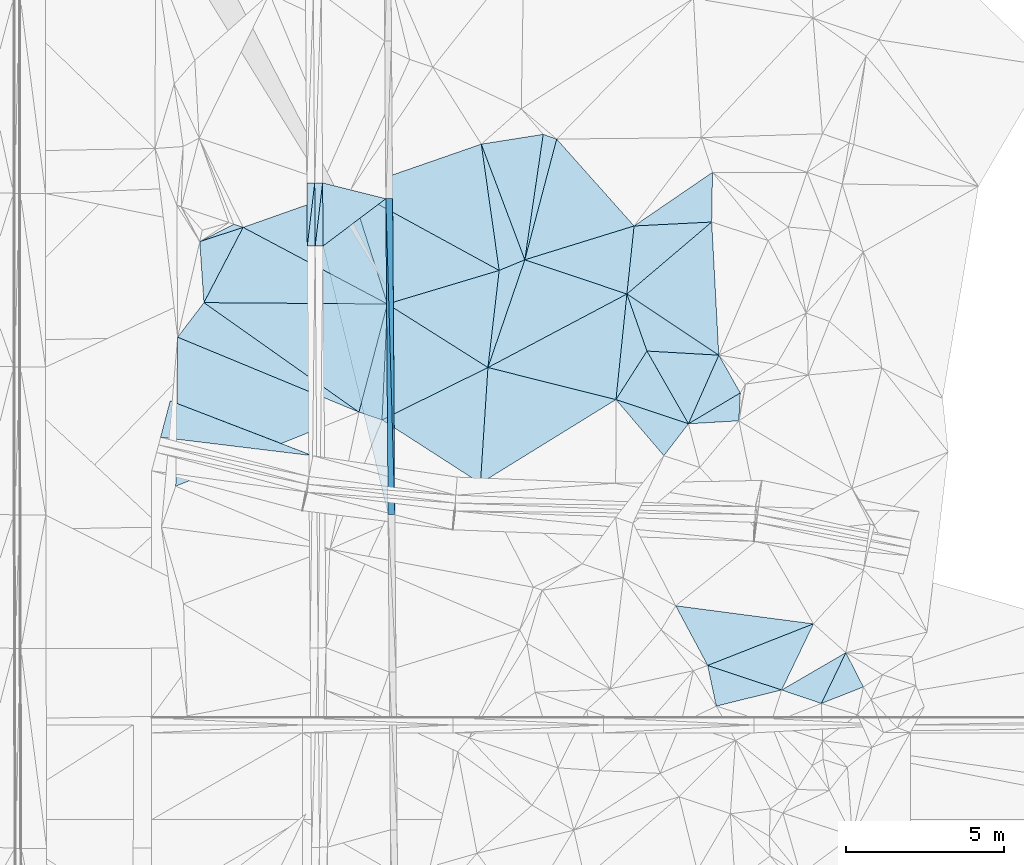
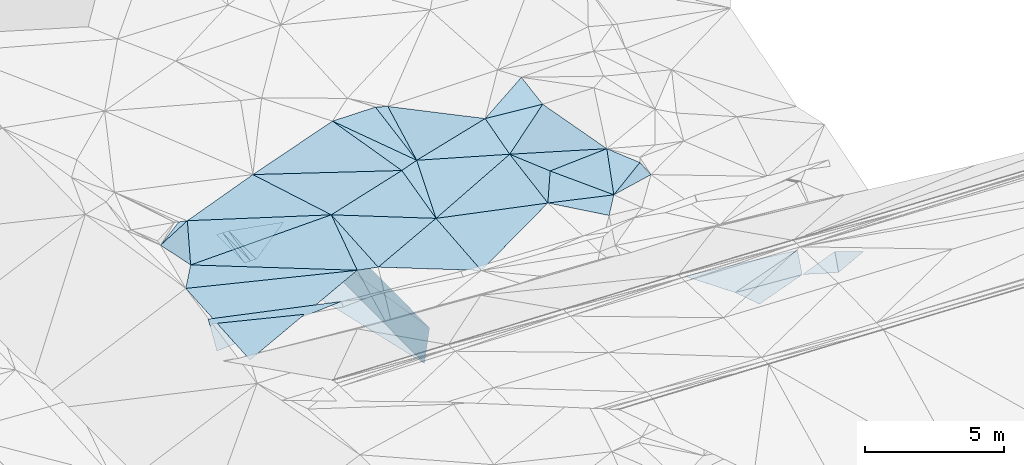
# One storey, part 116 of 275: 46 plates.
"""IFC2X3 building model written with IfcOpenShell, lengths in millimetres."""

from ifc_helpers import new_model, si_unit, frame, origin_with_axes, place, context, subcontext, project, spatial, polyline, outline, extrude, material, type_object, element, save


model = new_model("IFC2X3")

# Units and contexts
model_context = context("Model", 3, precision=1e-05, world=origin_with_axes())
body_context = subcontext(model_context, "Body", "Model", "MODEL_VIEW")
ifc_project = project(units=[si_unit("LENGTHUNIT", "METRE", prefix="MILLI"), si_unit("AREAUNIT", "SQUARE_METRE"), si_unit("VOLUMEUNIT", "CUBIC_METRE"), si_unit("MASSUNIT", "GRAM", prefix="KILO"), si_unit("TIMEUNIT", "SECOND"), si_unit("PLANEANGLEUNIT", "RADIAN"), si_unit("SOLIDANGLEUNIT", "STERADIAN"), si_unit("THERMODYNAMICTEMPERATUREUNIT", "DEGREE_CELSIUS"), si_unit("LUMINOUSINTENSITYUNIT", "LUMEN")], contexts=[model_context])

# Site, building, storey
site_placement = place(None, origin_with_axes())
site = spatial("IfcSite", under=ifc_project, at=site_placement, CompositionType="ELEMENT")
building_placement = place(site_placement, origin_with_axes())
building = spatial("IfcBuilding", under=site, at=building_placement, Name="Undefined", CompositionType="ELEMENT")
storey_placement = place(building_placement, origin_with_axes())
storey = spatial("IfcBuildingStorey", under=building, at=storey_placement, Name="Undefined", CompositionType="ELEMENT", Elevation=0.0)

# Plates
ifc_material = material()
plate_type_1 = type_object("IfcPlateType", PredefinedType="NOTDEFINED")
for number, where, z_axis, x_axis, name in (
    (1, (-45611.440829726, 82967.0120838289, 44497.5562892656), (0.989902956961609, 0.00960655166815321, -0.141420825777922), (0.00717853000557459, -0.999818122057876, -0.0176689420062705), "00_PR"),
    (2, (-45753.9243858585, 72965.7320617244, 42820.8392896904), (0.989902956961609, 0.00960655166815321, -0.141420825777922), (-0.0071785300206277, 0.999818122057271, 0.0176689420344176), "00_PR"),
):
    element("IfcPlate", number, at=place(storey_placement, frame(where, z_axis=z_axis, x_axis=x_axis)), inside=storey, type_object=plate_type_1, material=ifc_material, Name=name, context=body_context, shape_type="SweptSolid", body=[
        extrude(outline(polyline([(0.0, 0.0), (10001.560546875, 5.16956788487732e-08), (26.5030288696289, 1514.99694824219), (0.0, 0.0)])), frame((-8.85201319254618e-08, 2.18876761149539e-07, -0.5000001331573), z_axis=(0.0, 0.0, 1.0), x_axis=(1.0, 0.0, 0.0)), (0.0, 0.0, 1.0), 1.0),
    ])
plate_type_2 = type_object("IfcPlateType", PredefinedType="NOTDEFINED")
plate_1_placement = place(storey_placement, frame((-48065.5437276125, 81467.5205693756, 42982.9697085098), z_axis=(-0.0500599709306128, 0.0180559213872671, -0.998582987544492), x_axis=(-0.00717848200784323, 0.999804238048208, 0.0184378680141225)))
element("IfcPlate", 3, at=plate_1_placement, inside=storey, type_object=plate_type_2, material=ifc_material, Name="00_PR", context=body_context, shape_type="SweptSolid", body=[
    extrude(outline(polyline([(0.0, 0.0), (2000.33972167969, 1.37588358484209e-08), (2000.10900878906, 250.312652587891), (0.0, 0.0)])), frame((-8.85201319254618e-08, 2.18876761149539e-07, -0.5000001331573), z_axis=(0.0, 0.0, 1.0), x_axis=(1.0, 0.0, 0.0)), (0.0, 0.0, 1.0), 1.0),
])
plate_2_placement = place(storey_placement, frame((-48079.8681729223, 83467.4689445534, 43019.851185194), z_axis=(0.0198597143243329, 0.0185772484822645, -0.999630170405928), x_axis=(0.0071784820166339, -0.999804238047834, -0.0184378680309524)))
element("IfcPlate", 4, at=plate_2_placement, inside=storey, type_object=plate_type_2, material=ifc_material, Name="00_PR", context=body_context, shape_type="SweptSolid", body=[
    extrude(outline(polyline([(0.0, 0.0), (2000.33972167969, 1.37588358484209e-08), (2000.43176269531, 250.050430297852), (0.0, 0.0)])), frame((-8.85201319254618e-08, 2.18876761149539e-07, -0.5000001331573), z_axis=(0.0, 0.0, 1.0), x_axis=(1.0, 0.0, 0.0)), (0.0, 0.0, 1.0), 1.0),
])
plate_3_placement = place(storey_placement, frame((-47829.9091258811, 83469.2634174571, 43007.3517087475), z_axis=(-0.0500599709306128, 0.0180559213872671, -0.998582987544492), x_axis=(0.0071784820166339, -0.999804238047834, -0.0184378680309524)))
element("IfcPlate", 5, at=plate_3_placement, inside=storey, type_object=plate_type_2, material=ifc_material, Name="00_PR", context=body_context, shape_type="SweptSolid", body=[
    extrude(outline(polyline([(0.0, 0.0), (2000.34008789063, 9.45874489843845e-10), (2000.10913085938, 250.311737060547), (0.0, 0.0)])), frame((-8.85201319254618e-08, 2.18876761149539e-07, -0.5000001331573), z_axis=(0.0, 0.0, 1.0), x_axis=(1.0, 0.0, 0.0)), (0.0, 0.0, 1.0), 1.0),
])
plate_4_placement = place(storey_placement, frame((-48315.5027726976, 81465.726095695, 42977.9691854016), z_axis=(0.0198597143243329, 0.0185772484822645, -0.999630170405928), x_axis=(-0.00717848200784323, 0.999804238048208, 0.0184378680141225)))
element("IfcPlate", 6, at=plate_4_placement, inside=storey, type_object=plate_type_2, material=ifc_material, Name="00_PR", context=body_context, shape_type="SweptSolid", body=[
    extrude(outline(polyline([(0.0, 0.0), (2000.33972167969, 1.37588358484209e-08), (2000.43176269531, 250.050430297852), (0.0, 0.0)])), frame((-8.85201319254618e-08, 2.18876761149539e-07, -0.5000001331573), z_axis=(0.0, 0.0, 1.0), x_axis=(1.0, 0.0, 0.0)), (0.0, 0.0, 1.0), 1.0),
])
plate_type_3 = type_object("IfcPlateType", PredefinedType="NOTDEFINED")
plate_5_placement = place(storey_placement, frame((-47829.8843248077, 83469.2636118121, 43007.351084907), z_axis=(-0.000466637148883762, 0.0184349888689833, -0.999829952259469), x_axis=(0.969803099053307, -0.243839006006349, -0.00494855700560954)))
element("IfcPlate", 7, at=plate_5_placement, inside=storey, type_object=plate_type_3, material=ifc_material, Name="00_PR", context=body_context, shape_type="SweptSolid", body=[
    extrude(outline(polyline([(0.0, 0.0), (2066.05688476563, -1.94995664060116e-09), (501.772888183594, 1936.38439941406), (0.0, 0.0)])), frame((-8.85201319254618e-08, 2.18876761149539e-07, -0.5000001331573), z_axis=(0.0, 0.0, 1.0), x_axis=(1.0, 0.0, 0.0)), (0.0, 0.0, 1.0), 1.0),
])
plate_type_4 = type_object("IfcPlateType", PredefinedType="NOTDEFINED")
plate_6_placement = place(storey_placement, frame((-45826.2157859066, 82965.4779998254, 42997.1270785554), z_axis=(0.000108764896795697, 0.0176701778734708, -0.999843864302881), x_axis=(0.00717853000557459, -0.999818122057876, -0.0176689420062705)))
element("IfcPlate", 8, at=plate_6_placement, inside=storey, type_object=plate_type_4, material=ifc_material, Name="00_PR", context=body_context, shape_type="SweptSolid", body=[
    extrude(outline(polyline([(0.0, 0.0), (10001.560546875, 5.16956788487732e-08), (1482.08190917969, 2000.00048828125), (0.0, 0.0)])), frame((-8.85201319254618e-08, 2.18876761149539e-07, -0.5000001331573), z_axis=(0.0, 0.0, 1.0), x_axis=(1.0, 0.0, 0.0)), (0.0, 0.0, 1.0), 1.0),
])
plate_type_5 = type_object("IfcPlateType", PredefinedType="NOTDEFINED")
plate_7_placement = place(storey_placement, frame((-32023.6353352076, 66970.1824867202, 45649.5083263429), z_axis=(-0.117285743878101, -0.138926714673111, -0.983332813564714), x_axis=(-0.94497626087092, 0.320102275322519, 0.0674862928583433)))
element("IfcPlate", 9, at=plate_7_placement, inside=storey, type_object=plate_type_5, material=ifc_material, Name="00", context=body_context, shape_type="SweptSolid", body=[
    extrude(outline(polyline([(0.0, 0.0), (1333.60412597656, 6.25732354819775e-10), (-238.151626586914, 1800.24548339844), (0.0, 0.0)])), frame((-8.85201319254618e-08, 2.18876761149539e-07, -0.5000001331573), z_axis=(0.0, 0.0, 1.0), x_axis=(1.0, 0.0, 0.0)), (0.0, 0.0, 1.0), 1.0),
])
plate_type_6 = type_object("IfcPlateType", PredefinedType="NOTDEFINED")
plate_8_placement = place(storey_placement, frame((-42590.7508300564, 77616.6357043385, 45269.5010338219), z_axis=(-0.051957473018278, 0.0382523174935054, -0.997916419949051), x_axis=(0.323926792475622, 0.945883383379126, 0.0193922191538726)))
element("IfcPlate", 10, at=plate_8_placement, inside=storey, type_object=plate_type_6, material=ifc_material, Name="00", context=body_context, shape_type="SweptSolid", body=[
    extrude(outline(polyline([(0.0, 0.0), (3609.6953125, 2.17260094359517e-08), (3627.50830078125, 3418.21337890625), (0.0, 0.0)])), frame((-8.85201319254618e-08, 2.18876761149539e-07, -0.5000001331573), z_axis=(0.0, 0.0, 1.0), x_axis=(1.0, 0.0, 0.0)), (0.0, 0.0, 1.0), 1.0),
])
plate_type_7 = type_object("IfcPlateType", PredefinedType="NOTDEFINED")
plate_9_placement = place(storey_placement, frame((-52964.5569480479, 75407.0896281974, 44415.7057698701), z_axis=(0.204699811996675, 0.406415565494223, -0.890463011636383), x_axis=(0.228565604914769, 0.864729947873355, 0.447213463013906)))
element("IfcPlate", 11, at=plate_9_placement, inside=storey, type_object=plate_type_7, material=ifc_material, Name="00_PR", context=body_context, shape_type="SweptSolid", body=[
    extrude(outline(polyline([(0.0, 0.0), (1334.58862304688, 4.36557456851006e-09), (973.793395996094, 4840.79736328125), (0.0, 0.0)])), frame((-8.85201319254618e-08, 2.18876761149539e-07, -0.5000001331573), z_axis=(0.0, 0.0, 1.0), x_axis=(1.0, 0.0, 0.0)), (0.0, 0.0, 1.0), 1.0),
])
plate_type_8 = type_object("IfcPlateType", PredefinedType="NOTDEFINED")
plate_10_placement = place(storey_placement, frame((-50349.2865730213, 82058.7114239253, 45189.5204353635), z_axis=(0.260230933782601, -0.111289137762147, -0.959111353763886), x_axis=(-0.461481922297467, -0.886869169009818, -0.0223049871658503)))
element("IfcPlate", 12, at=plate_10_placement, inside=storey, type_object=plate_type_8, material=ifc_material, Name="00", context=body_context, shape_type="SweptSolid", body=[
    extrude(outline(polyline([(0.0, 0.0), (2689.9814453125, -6.34463503956795e-09), (1043.87341308594, 1051.63122558594), (0.0, 0.0)])), frame((-8.85201319254618e-08, 2.18876761149539e-07, -0.5000001331573), z_axis=(0.0, 0.0, 1.0), x_axis=(1.0, 0.0, 0.0)), (0.0, 0.0, 1.0), 1.0),
])
plate_type_9 = type_object("IfcPlateType", PredefinedType="NOTDEFINED")
plate_11_placement = place(storey_placement, frame((-38533.352089813, 76600.4152492444, 45139.5000567552), z_axis=(0.0121856490326981, 0.0104083737287449, -0.999871579611089), x_axis=(0.948449290462137, -0.316821243510235, 0.00826093714398372)))
element("IfcPlate", 13, at=plate_11_placement, inside=storey, type_object=plate_type_9, material=ifc_material, Name="00", context=body_context, shape_type="SweptSolid", body=[
    extrude(outline(polyline([(0.0, 0.0), (2421.03295898438, 5.79166226089001e-09), (2003.48376464844, 1205.21899414063), (0.0, 0.0)])), frame((-8.85201319254618e-08, 2.18876761149539e-07, -0.5000001331573), z_axis=(0.0, 0.0, 1.0), x_axis=(1.0, 0.0, 0.0)), (0.0, 0.0, 1.0), 1.0),
])
plate_type_10 = type_object("IfcPlateType", PredefinedType="NOTDEFINED")
plate_12_placement = place(storey_placement, frame((-42590.7583855157, 77616.6382808474, 45269.5015902507), z_axis=(-0.0670680897635181, 0.0434042828429216, -0.996803862134555), x_axis=(0.114971573375431, 0.992734554038146, 0.0354914431132505)))
element("IfcPlate", 14, at=plate_12_placement, inside=storey, type_object=plate_type_10, material=ifc_material, Name="00", context=body_context, shape_type="SweptSolid", body=[
    extrude(outline(polyline([(0.0, 0.0), (3099.33862304688, -1.24346115626395e-08), (3526.4619140625, 770.691650390625), (0.0, 0.0)])), frame((-8.85201319254618e-08, 2.18876761149539e-07, -0.5000001331573), z_axis=(0.0, 0.0, 1.0), x_axis=(1.0, 0.0, 0.0)), (0.0, 0.0, 1.0), 1.0),
])
plate_type_11 = type_object("IfcPlateType", PredefinedType="NOTDEFINED")
plate_13_placement = place(storey_placement, frame((-37959.0555084484, 82102.5127284734, 45309.502199077), z_axis=(-0.0355071500618557, 0.0868618991051174, -0.995587390829322), x_axis=(-0.104619701305093, -0.991064808602268, -0.0827361060782031)))
element("IfcPlate", 15, at=plate_13_placement, inside=storey, type_object=plate_type_11, material=ifc_material, Name="00", context=body_context, shape_type="SweptSolid", body=[
    extrude(outline(polyline([(0.0, 0.0), (2175.591796875, 1.73167791217566e-09), (1421.68212890625, 3334.08447265625), (0.0, 0.0)])), frame((-8.85201319254618e-08, 2.18876761149539e-07, -0.5000001331573), z_axis=(0.0, 0.0, 1.0), x_axis=(1.0, 0.0, 0.0)), (0.0, 0.0, 1.0), 1.0),
])
plate_type_12 = type_object("IfcPlateType", PredefinedType="NOTDEFINED")
plate_14_placement = place(storey_placement, frame((-35628.7499506837, 68175.4182731513, 45299.5005560244), z_axis=(-0.0150729530289691, -0.0450021216840789, -0.998873172695572), x_axis=(-0.471159090649724, 0.881445532979913, -0.0326018969982285)))
element("IfcPlate", 16, at=plate_14_placement, inside=storey, type_object=plate_type_12, material=ifc_material, Name="00", context=body_context, shape_type="SweptSolid", body=[
    extrude(outline(polyline([(0.0, 0.0), (2147.1142578125, 1.1467363947304e-08), (-414.183807373047, 3580.92895507813), (0.0, 0.0)])), frame((-8.85201319254618e-08, 2.18876761149539e-07, -0.5000001331573), z_axis=(0.0, 0.0, 1.0), x_axis=(1.0, 0.0, 0.0)), (0.0, 0.0, 1.0), 1.0),
])
plate_type_13 = type_object("IfcPlateType", PredefinedType="NOTDEFINED")
plate_15_placement = place(storey_placement, frame((-33283.7595961247, 67396.9967340516, 45739.5232507275), z_axis=(0.0826977127067157, -0.289877887958452, -0.953484083970899), x_axis=(-0.934387954989885, 0.310128554392591, -0.175326636083003)))
element("IfcPlate", 17, at=plate_15_placement, inside=storey, type_object=plate_type_13, material=ifc_material, Name="00", context=body_context, shape_type="SweptSolid", body=[
    extrude(outline(polyline([(0.0, 0.0), (2509.6015625, -6.67932908982039e-09), (-195.449356079102, 2382.70849609375), (0.0, 0.0)])), frame((-8.85201319254618e-08, 2.18876761149539e-07, -0.5000001331573), z_axis=(0.0, 0.0, 1.0), x_axis=(1.0, 0.0, 0.0)), (0.0, 0.0, 1.0), 1.0),
])
plate_type_14 = type_object("IfcPlateType", PredefinedType="NOTDEFINED")
plate_16_placement = place(storey_placement, frame((-35474.2548705891, 83802.4298507514, 45219.5092149596), z_axis=(-0.130809075359765, 0.139243313183833, -0.981580503849334), x_axis=(-0.0159907927948553, -0.990255289562894, -0.138342892981534)))
element("IfcPlate", 18, at=plate_16_placement, inside=storey, type_object=plate_type_14, material=ifc_material, Name="00", context=body_context, shape_type="SweptSolid", body=[
    extrude(outline(polyline([(0.0, 0.0), (1590.25158691406, 3.66708263754845e-09), (1710.60986328125, 2479.11547851563), (0.0, 0.0)])), frame((-8.85201319254618e-08, 2.18876761149539e-07, -0.5000001331573), z_axis=(0.0, 0.0, 1.0), x_axis=(1.0, 0.0, 0.0)), (0.0, 0.0, 1.0), 1.0),
])
plate_type_15 = type_object("IfcPlateType", PredefinedType="NOTDEFINED")
plate_17_placement = place(storey_placement, frame((-35274.338399379, 78008.4605662626, 45529.5059452335), z_axis=(0.068118107248955, 0.137936519053203, -0.988095865883622), x_axis=(0.493358567752894, -0.865483453004817, -0.0868085030378525)))
element("IfcPlate", 19, at=plate_17_placement, inside=storey, type_object=plate_type_15, material=ifc_material, Name="00", context=body_context, shape_type="SweptSolid", body=[
    extrude(outline(polyline([(0.0, 0.0), (1382.35302734375, -1.48247636388987e-09), (1439.57434082031, 1929.28112792969), (0.0, 0.0)])), frame((-8.85201319254618e-08, 2.18876761149539e-07, -0.5000001331573), z_axis=(0.0, 0.0, 1.0), x_axis=(1.0, 0.0, 0.0)), (0.0, 0.0, 1.0), 1.0),
])
plate_type_16 = type_object("IfcPlateType", PredefinedType="NOTDEFINED")
plate_18_placement = place(storey_placement, frame((-35628.6676769151, 68175.3880582207, 45299.5084282961), z_axis=(0.149477538857927, -0.105435131521597, -0.983127610444341), x_axis=(0.934387954990388, -0.310128554395548, 0.175326636075094)))
element("IfcPlate", 20, at=plate_18_placement, inside=storey, type_object=plate_type_16, material=ifc_material, Name="00", context=body_context, shape_type="SweptSolid", body=[
    extrude(outline(polyline([(0.0, 0.0), (2509.6015625, -6.67932908982039e-09), (687.957824707031, 1138.47009277344), (0.0, 0.0)])), frame((-8.85201319254618e-08, 2.18876761149539e-07, -0.5000001331573), z_axis=(0.0, 0.0, 1.0), x_axis=(1.0, 0.0, 0.0)), (0.0, 0.0, 1.0), 1.0),
])
plate_type_17 = type_object("IfcPlateType", PredefinedType="NOTDEFINED")
plate_19_placement = place(storey_placement, frame((-45946.6400284394, 75958.0347915587, 45309.500417182), z_axis=(0.0412451024991055, 0.000815216760134066, -0.999148726137141), x_axis=(-0.94747696147738, 0.317455267521133, -0.0388530641349896)))
element("IfcPlate", 21, at=plate_19_placement, inside=storey, type_object=plate_type_17, material=ifc_material, Name="00", context=body_context, shape_type="SweptSolid", body=[
    extrude(outline(polyline([(0.0, 0.0), (772.139892578125, 2.14640749618411e-09), (1004.61071777344, 3536.17846679688), (0.0, 0.0)])), frame((-8.85201319254618e-08, 2.18876761149539e-07, -0.5000001331573), z_axis=(0.0, 0.0, 1.0), x_axis=(1.0, 0.0, 0.0)), (0.0, 0.0, 1.0), 1.0),
])
plate_type_18 = type_object("IfcPlateType", PredefinedType="NOTDEFINED")
plate_20_placement = place(storey_placement, frame((-42801.238001194, 84696.026586811, 45319.5005112459), z_axis=(-0.0405512321685537, -0.020717374984884, -0.998962655930314), x_axis=(0.352320463713283, -0.935865487109093, 0.00510694496915836)))
element("IfcPlate", 22, at=plate_20_placement, inside=storey, type_object=plate_type_18, material=ifc_material, Name="00", context=body_context, shape_type="SweptSolid", body=[
    extrude(outline(polyline([(0.0, 0.0), (3916.2353515625, 1.22345227282494e-08), (3945.90673828125, 880.635925292969), (0.0, 0.0)])), frame((-8.85201319254618e-08, 2.18876761149539e-07, -0.5000001331573), z_axis=(0.0, 0.0, 1.0), x_axis=(1.0, 0.0, 0.0)), (0.0, 0.0, 1.0), 1.0),
])
plate_type_19 = type_object("IfcPlateType", PredefinedType="NOTDEFINED")
plate_21_placement = place(storey_placement, frame((-45777.0021280551, 79630.2171103815, 45319.5000403417), z_axis=(-0.0135736897279932, 0.00335005483314225, -0.999902261263461), x_axis=(0.845268668731747, -0.53417687874502, -0.013264232909917)))
element("IfcPlate", 23, at=plate_21_placement, inside=storey, type_object=plate_type_19, material=ifc_material, Name="00", context=body_context, shape_type="SweptSolid", body=[
    extrude(outline(polyline([(0.0, 0.0), (3769.53588867188, -1.87064870260656e-08), (1818.31408691406, 3194.92309570313), (0.0, 0.0)])), frame((-8.85201319254618e-08, 2.18876761149539e-07, -0.5000001331573), z_axis=(0.0, 0.0, 1.0), x_axis=(1.0, 0.0, 0.0)), (0.0, 0.0, 1.0), 1.0),
])
plate_type_20 = type_object("IfcPlateType", PredefinedType="NOTDEFINED")
plate_22_placement = place(storey_placement, frame((-51722.9953657232, 81604.6992951105, 44869.5248348036), z_axis=(0.127472605050266, 0.284005086141741, -0.950311446846412), x_axis=(0.861979620139867, 0.44225479875001, 0.247793921326006)))
element("IfcPlate", 24, at=plate_22_placement, inside=storey, type_object=plate_type_20, material=ifc_material, Name="00", context=body_context, shape_type="SweptSolid", body=[
    extrude(outline(polyline([(0.0, 0.0), (1251.03955078125, -8.73114913702011e-11), (1464.22229003906, 227.273254394531), (0.0, 0.0)])), frame((-8.85201319254618e-08, 2.18876761149539e-07, -0.5000001331573), z_axis=(0.0, 0.0, 1.0), x_axis=(1.0, 0.0, 0.0)), (0.0, 0.0, 1.0), 1.0),
])
plate_type_21 = type_object("IfcPlateType", PredefinedType="NOTDEFINED")
plate_23_placement = place(storey_placement, frame((-38186.7121664993, 79946.3647838782, 45129.5065202402), z_axis=(-0.129287103128676, 0.0960401308193776, -0.986945357269992), x_axis=(0.104619701351834, 0.991064808599203, 0.0827361060558137)))
element("IfcPlate", 25, at=plate_23_placement, inside=storey, type_object=plate_type_21, material=ifc_material, Name="00", context=body_context, shape_type="SweptSolid", body=[
    extrude(outline(polyline([(0.0, 0.0), (2175.591796875, 1.73167791217566e-09), (2531.26513671875, 2456.41943359375), (0.0, 0.0)])), frame((-8.85201319254618e-08, 2.18876761149539e-07, -0.5000001331573), z_axis=(0.0, 0.0, 1.0), x_axis=(1.0, 0.0, 0.0)), (0.0, 0.0, 1.0), 1.0),
])
plate_type_22 = type_object("IfcPlateType", PredefinedType="NOTDEFINED")
plate_24_placement = place(storey_placement, frame((-46678.2195650224, 76203.1692612606, 45279.5008848769), z_axis=(0.0516759894621313, 0.0300087490568013, -0.998212936749046), x_axis=(-0.923493412005556, 0.381890357341918, -0.0363273031148638)))
element("IfcPlate", 26, at=plate_24_placement, inside=storey, type_object=plate_type_22, material=ifc_material, Name="00", context=body_context, shape_type="SweptSolid", body=[
    extrude(outline(polyline([(0.0, 0.0), (6221.2158203125, -6.30097929388285e-09), (5867.296875, 1330.80017089844), (0.0, 0.0)])), frame((-8.85201319254618e-08, 2.18876761149539e-07, -0.5000001331573), z_axis=(0.0, 0.0, 1.0), x_axis=(1.0, 0.0, 0.0)), (0.0, 0.0, 1.0), 1.0),
])
plate_type_23 = type_object("IfcPlateType", PredefinedType="NOTDEFINED")
plate_25_placement = place(storey_placement, frame((-38186.5667848983, 79946.3069160925, 45129.506653201), z_axis=(0.161482864789246, -0.0196821453512393, -0.986679227273905), x_axis=(0.330613598568115, -0.940948076776663, 0.0728791139637385)))
element("IfcPlate", 27, at=plate_25_placement, inside=storey, type_object=plate_type_23, material=ifc_material, Name="00", context=body_context, shape_type="SweptSolid", body=[
    extrude(outline(polyline([(0.0, 0.0), (1920.98937988281, -1.25282895169221e-08), (3034.42602539063, 1451.77783203125), (0.0, 0.0)])), frame((-8.85201319254618e-08, 2.18876761149539e-07, -0.5000001331573), z_axis=(0.0, 0.0, 1.0), x_axis=(1.0, 0.0, 0.0)), (0.0, 0.0, 1.0), 1.0),
])
plate_type_24 = type_object("IfcPlateType", PredefinedType="NOTDEFINED")
plate_26_placement = place(storey_placement, frame((-31248.648056444, 68580.9616521498, 45329.531409766), z_axis=(0.202940289696192, -0.283785851259777, -0.93716638300933), x_axis=(0.427975224467827, -0.83511947682967, 0.345561379007336)))
element("IfcPlate", 28, at=plate_26_placement, inside=storey, type_object=plate_type_24, material=ifc_material, Name="00", context=body_context, shape_type="SweptSolid", body=[
    extrude(outline(polyline([(0.0, 0.0), (1302.22888183594, 9.0003595687449e-09), (1124.22631835938, 1426.08386230469), (0.0, 0.0)])), frame((-8.85201319254618e-08, 2.18876761149539e-07, -0.5000001331573), z_axis=(0.0, 0.0, 1.0), x_axis=(1.0, 0.0, 0.0)), (0.0, 0.0, 1.0), 1.0),
])
plate_type_25 = type_object("IfcPlateType", PredefinedType="NOTDEFINED")
plate_27_placement = place(storey_placement, frame((-40839.001652392, 85005.8985560776, 45059.502826315), z_axis=(-0.0898181556168045, -0.0568797879605049, -0.994332634807469), x_axis=(0.941389601385608, -0.330778724472028, -0.066113945879095)))
element("IfcPlate", 29, at=plate_27_placement, inside=storey, type_object=plate_type_25, material=ifc_material, Name="00", context=body_context, shape_type="SweptSolid", body=[
    extrude(outline(polyline([(0.0, 0.0), (453.762054443359, -2.29556462727487e-09), (747.969116210938, 3957.08764648438), (0.0, 0.0)])), frame((-8.85201319254618e-08, 2.18876761149539e-07, -0.5000001331573), z_axis=(0.0, 0.0, 1.0), x_axis=(1.0, 0.0, 0.0)), (0.0, 0.0, 1.0), 1.0),
])
plate_type_26 = type_object("IfcPlateType", PredefinedType="NOTDEFINED")
plate_28_placement = place(storey_placement, frame((-40411.7809618619, 84855.7894432306, 45029.5019006205), z_axis=(0.0178096272590279, -0.0854405878997472, -0.99618408093898), x_axis=(0.663259744435742, -0.74454925257556, 0.0757160610452599)))
element("IfcPlate", 30, at=plate_28_placement, inside=storey, type_object=plate_type_26, material=ifc_material, Name="00", context=body_context, shape_type="SweptSolid", body=[
    extrude(outline(polyline([(0.0, 0.0), (3698.02661132813, 1.55523594003171e-08), (2201.60668945313, 3301.21606445313), (0.0, 0.0)])), frame((-8.85201319254618e-08, 2.18876761149539e-07, -0.5000001331573), z_axis=(0.0, 0.0, 1.0), x_axis=(1.0, 0.0, 0.0)), (0.0, 0.0, 1.0), 1.0),
])
plate_type_27 = type_object("IfcPlateType", PredefinedType="NOTDEFINED")
plate_29_placement = place(storey_placement, frame((-41421.5094076723, 81030.9414754924, 45339.5044728246), z_axis=(-0.123137822246481, -0.0517650824391341, -0.991038572898383), x_axis=(-0.352320463708252, 0.935865487110964, -0.00510694497342633)))
element("IfcPlate", 31, at=plate_29_placement, inside=storey, type_object=plate_type_27, material=ifc_material, Name="00", context=body_context, shape_type="SweptSolid", body=[
    extrude(outline(polyline([(0.0, 0.0), (3916.2353515625, 1.22345227282494e-08), (3516.23388671875, 1963.18591308594), (0.0, 0.0)])), frame((-8.85201319254618e-08, 2.18876761149539e-07, -0.5000001331573), z_axis=(0.0, 0.0, 1.0), x_axis=(1.0, 0.0, 0.0)), (0.0, 0.0, 1.0), 1.0),
])
plate_type_28 = type_object("IfcPlateType", PredefinedType="NOTDEFINED")
plate_30_placement = place(storey_placement, frame((-42234.3830762371, 80693.4304850533, 45379.5000715837), z_axis=(0.0118726229729693, -0.0133065296016423, -0.999840975902519), x_axis=(-0.877360113062365, 0.479538303311504, -0.0168002281031586)))
element("IfcPlate", 32, at=plate_30_placement, inside=storey, type_object=plate_type_28, material=ifc_material, Name="00", context=body_context, shape_type="SweptSolid", body=[
    extrude(outline(polyline([(0.0, 0.0), (5357.0703125, -1.47047103382647e-08), (2417.72094726563, 3240.42065429688), (0.0, 0.0)])), frame((-8.85201319254618e-08, 2.18876761149539e-07, -0.5000001331573), z_axis=(0.0, 0.0, 1.0), x_axis=(1.0, 0.0, 0.0)), (0.0, 0.0, 1.0), 1.0),
])
plate_type_29 = type_object("IfcPlateType", PredefinedType="NOTDEFINED")
plate_31_placement = place(storey_placement, frame((-38186.5919171278, 79946.2978371215, 45129.5034551462), z_axis=(0.111219838277662, -0.0378380633196846, -0.993075238105203), x_axis=(0.827133943268094, -0.550402568449124, 0.113606569081109)))
element("IfcPlate", 33, at=plate_31_placement, inside=storey, type_object=plate_type_29, material=ifc_material, Name="00", context=body_context, shape_type="SweptSolid", body=[
    extrude(outline(polyline([(0.0, 0.0), (3520.92309570313, -4.59840521216393e-09), (1536.10278320313, 1153.51123046875), (0.0, 0.0)])), frame((-8.85201319254618e-08, 2.18876761149539e-07, -0.5000001331573), z_axis=(0.0, 0.0, 1.0), x_axis=(1.0, 0.0, 0.0)), (0.0, 0.0, 1.0), 1.0),
])
plate_type_30 = type_object("IfcPlateType", PredefinedType="NOTDEFINED")
plate_32_placement = place(storey_placement, frame((-46934.459776401, 83262.3561383767, 45289.5000717086), z_axis=(0.0177178944870879, -0.00261201171434561, -0.999839613943031), x_axis=(0.877360113056867, -0.47953830332173, 0.0168002280984157)))
element("IfcPlate", 34, at=plate_32_placement, inside=storey, type_object=plate_type_30, material=ifc_material, Name="00", context=body_context, shape_type="SweptSolid", body=[
    extrude(outline(polyline([(0.0, 0.0), (5357.0703125, -1.47047103382647e-08), (2757.77612304688, 2632.06591796875), (0.0, 0.0)])), frame((-8.85201319254618e-08, 2.18876761149539e-07, -0.5000001331573), z_axis=(0.0, 0.0, 1.0), x_axis=(1.0, 0.0, 0.0)), (0.0, 0.0, 1.0), 1.0),
])
plate_type_31 = type_object("IfcPlateType", PredefinedType="NOTDEFINED")
plate_33_placement = place(storey_placement, frame((-45776.9808763893, 79630.2159186291, 45319.5002012288), z_axis=(0.0289311632876756, 0.000963514197316126, -0.999580941910766), x_axis=(-0.88288122972571, 0.468924993675319, -0.0251014841119047)))
element("IfcPlate", 35, at=plate_33_placement, inside=storey, type_object=plate_type_31, material=ifc_material, Name="00", context=body_context, shape_type="SweptSolid", body=[
    extrude(outline(polyline([(0.0, 0.0), (5178.9765625, -1.45519152283669e-11), (2725.86669921875, 2665.0986328125), (0.0, 0.0)])), frame((-8.85201319254618e-08, 2.18876761149539e-07, -0.5000001331573), z_axis=(0.0, 0.0, 1.0), x_axis=(1.0, 0.0, 0.0)), (0.0, 0.0, 1.0), 1.0),
])
plate_type_32 = type_object("IfcPlateType", PredefinedType="NOTDEFINED")
plate_34_placement = place(storey_placement, frame((-38186.6634986237, 79946.31691914, 45129.5002480479), z_axis=(-0.0319432766274098, 0.000322835376601835, -0.999489631189651), x_axis=(-0.1030699903158, -0.994669663547129, 0.00297279587951284)))
element("IfcPlate", 36, at=plate_34_placement, inside=storey, type_object=plate_type_32, material=ifc_material, Name="00", context=body_context, shape_type="SweptSolid", body=[
    extrude(outline(polyline([(0.0, 0.0), (3363.83715820313, -2.12821760214865e-08), (2771.62646484375, 4142.59423828125), (0.0, 0.0)])), frame((-8.85201319254618e-08, 2.18876761149539e-07, -0.5000001331573), z_axis=(0.0, 0.0, 1.0), x_axis=(1.0, 0.0, 0.0)), (0.0, 0.0, 1.0), 1.0),
])
plate_type_33 = type_object("IfcPlateType", PredefinedType="NOTDEFINED")
plate_35_placement = place(storey_placement, frame((-34592.2925945982, 76811.9723344275, 45409.5073683958), z_axis=(0.168269701216, -0.0311153955073901, -0.985249785493555), x_axis=(-0.0523996523606445, -0.998370871744592, 0.0225804978782087)))
element("IfcPlate", 37, at=plate_35_placement, inside=storey, type_object=plate_type_33, material=ifc_material, Name="00", context=body_context, shape_type="SweptSolid", body=[
    extrude(outline(polyline([(0.0, 0.0), (885.720031738281, 3.88172338716686e-09), (1057.5576171875, 1614.61193847656), (0.0, 0.0)])), frame((-8.85201319254618e-08, 2.18876761149539e-07, -0.5000001331573), z_axis=(0.0, 0.0, 1.0), x_axis=(1.0, 0.0, 0.0)), (0.0, 0.0, 1.0), 1.0),
])
plate_type_34 = type_object("IfcPlateType", PredefinedType="NOTDEFINED")
plate_36_placement = place(storey_placement, frame((-50349.4003283079, 82058.7711220741, 45189.5002752426), z_axis=(0.0327221144742396, 0.0081090248700213, -0.999431591926127), x_axis=(0.882881229726438, -0.468924993673695, 0.0251014841166295)))
element("IfcPlate", 38, at=plate_36_placement, inside=storey, type_object=plate_type_34, material=ifc_material, Name="00", context=body_context, shape_type="SweptSolid", body=[
    extrude(outline(polyline([(0.0, 0.0), (5178.9765625, -1.45519152283669e-11), (21.201099395752, 2689.89794921875), (0.0, 0.0)])), frame((-8.85201319254618e-08, 2.18876761149539e-07, -0.5000001331573), z_axis=(0.0, 0.0, 1.0), x_axis=(1.0, 0.0, 0.0)), (0.0, 0.0, 1.0), 1.0),
])
plate_type_35 = type_object("IfcPlateType", PredefinedType="NOTDEFINED")
plate_37_placement = place(storey_placement, frame((-36237.1161199664, 75833.4078662501, 45159.50127804), z_axis=(0.0303689565532647, 0.0649063668783801, -0.997429140348584), x_axis=(-0.948449290459063, 0.316821243519592, -0.00826093713815015)))
element("IfcPlate", 39, at=plate_37_placement, inside=storey, type_object=plate_type_35, material=ifc_material, Name="00", context=body_context, shape_type="SweptSolid", body=[
    extrude(outline(polyline([(0.0, 0.0), (2421.03295898438, 5.79166226089001e-09), (1976.14001464844, 1774.67468261719), (0.0, 0.0)])), frame((-8.85201319254618e-08, 2.18876761149539e-07, -0.5000001331573), z_axis=(0.0, 0.0, 1.0), x_axis=(1.0, 0.0, 0.0)), (0.0, 0.0, 1.0), 1.0),
])
plate_type_36 = type_object("IfcPlateType", PredefinedType="NOTDEFINED")
plate_38_placement = place(storey_placement, frame((-45776.9789982362, 79630.2169696285, 45319.5002609763), z_axis=(0.0326858981178371, 0.00306976459596199, -0.99946095902219), x_axis=(-0.254316590392904, -0.967055153087336, -0.011287282142151)))
element("IfcPlate", 40, at=plate_38_placement, inside=storey, type_object=plate_type_36, material=ifc_material, Name="00", context=body_context, shape_type="SweptSolid", body=[
    extrude(outline(polyline([(0.0, 0.0), (3543.8115234375, -1.96669134311378e-08), (1439.21313476563, 5636.21044921875), (0.0, 0.0)])), frame((-8.85201319254618e-08, 2.18876761149539e-07, -0.5000001331573), z_axis=(0.0, 0.0, 1.0), x_axis=(1.0, 0.0, 0.0)), (0.0, 0.0, 1.0), 1.0),
])
plate_type_37 = type_object("IfcPlateType", PredefinedType="NOTDEFINED")
plate_39_placement = place(storey_placement, frame((-36237.071713134, 75833.4329163224, 45159.5068989081), z_axis=(0.119184393108084, 0.115007885689663, -0.986188758133376), x_axis=(-0.494874409546338, 0.867977030703215, 0.0414148879968707)))
element("IfcPlate", 41, at=plate_39_placement, inside=storey, type_object=plate_type_37, material=ifc_material, Name="00", context=body_context, shape_type="SweptSolid", body=[
    extrude(outline(polyline([(0.0, 0.0), (2656.0498046875, -1.05392246041447e-08), (1426.74291992188, 1938.78955078125), (0.0, 0.0)])), frame((-8.85201319254618e-08, 2.18876761149539e-07, -0.5000001331573), z_axis=(0.0, 0.0, 1.0), x_axis=(1.0, 0.0, 0.0)), (0.0, 0.0, 1.0), 1.0),
])
plate_type_38 = type_object("IfcPlateType", PredefinedType="NOTDEFINED")
plate_40_placement = place(storey_placement, frame((-42590.7216380054, 77616.6340709406, 45269.5003087025), z_axis=(0.00642632728674498, 0.0349843154117647, -0.999367199778327), x_axis=(-0.845268668738955, 0.534176878733605, 0.0132642329102666)))
element("IfcPlate", 42, at=plate_40_placement, inside=storey, type_object=plate_type_38, material=ifc_material, Name="00", context=body_context, shape_type="SweptSolid", body=[
    extrude(outline(polyline([(0.0, 0.0), (3769.53588867188, -1.87064870260656e-08), (1343.82592773438, 2792.85375976563), (0.0, 0.0)])), frame((-8.85201319254618e-08, 2.18876761149539e-07, -0.5000001331573), z_axis=(0.0, 0.0, 1.0), x_axis=(1.0, 0.0, 0.0)), (0.0, 0.0, 1.0), 1.0),
])
plate_type_39 = type_object("IfcPlateType", PredefinedType="NOTDEFINED")
plate_41_placement = place(storey_placement, frame((-42827.4016615265, 73947.6107078114, 45289.5000204188), z_axis=(-0.00952837194444339, -0.0048361247871663, -0.999942909382896), x_axis=(-0.840530721726339, 0.541737077740841, 0.00538928891538041)))
element("IfcPlate", 43, at=plate_41_placement, inside=storey, type_object=plate_type_39, material=ifc_material, Name="00", context=body_context, shape_type="SweptSolid", body=[
    extrude(outline(polyline([(0.0, 0.0), (3711.064453125, -1.55923771671951e-08), (1788.59729003906, 3212.3076171875), (0.0, 0.0)])), frame((-8.85201319254618e-08, 2.18876761149539e-07, -0.5000001331573), z_axis=(0.0, 0.0, 1.0), x_axis=(1.0, 0.0, 0.0)), (0.0, 0.0, 1.0), 1.0),
])
plate_type_40 = type_object("IfcPlateType", PredefinedType="NOTDEFINED")
plate_42_placement = place(storey_placement, frame((-42827.4133264133, 73947.6114621616, 45289.5002645823), z_axis=(-0.0328567014617355, -0.0033286494338036, -0.999454529862165), x_axis=(0.0643710733690234, 0.997911205840253, -0.00543968489643414)))
element("IfcPlate", 44, at=plate_42_placement, inside=storey, type_object=plate_type_40, material=ifc_material, Name="00", context=body_context, shape_type="SweptSolid", body=[
    extrude(outline(polyline([(0.0, 0.0), (3676.68334960938, 1.87719706445932e-09), (2924.48364257813, 4116.55126953125), (0.0, 0.0)])), frame((-8.85201319254618e-08, 2.18876761149539e-07, -0.5000001331573), z_axis=(0.0, 0.0, 1.0), x_axis=(1.0, 0.0, 0.0)), (0.0, 0.0, 1.0), 1.0),
])
plate_type_41 = type_object("IfcPlateType", PredefinedType="NOTDEFINED")
plate_43_placement = place(storey_placement, frame((-52484.5244146506, 73854.9111815666, 44799.5016220836), z_axis=(0.061043826024363, 0.0528025558297029, -0.996737448580196), x_axis=(0.0129050084190478, 0.998474531098614, 0.0536849281000412)))
element("IfcPlate", 45, at=plate_43_placement, inside=storey, type_object=plate_type_41, material=ifc_material, Name="00", context=body_context, shape_type="SweptSolid", body=[
    extrude(outline(polyline([(0.0, 0.0), (4731.3095703125, 2.45854607783258e-08), (2445.38647460938, 5786.02490234375), (0.0, 0.0)])), frame((-8.85201319254618e-08, 2.18876761149539e-07, -0.5000001331573), z_axis=(0.0, 0.0, 1.0), x_axis=(1.0, 0.0, 0.0)), (0.0, 0.0, 1.0), 1.0),
])
plate_type_42 = type_object("IfcPlateType", PredefinedType="NOTDEFINED")
plate_44_placement = place(storey_placement, frame((-35499.5913359123, 82227.54451554, 44999.5044715376), z_axis=(0.05524187640219, -0.12154215504867, -0.991047849317928), x_axis=(0.0528954556487797, -0.990813463225976, 0.124461849021519)))
element("IfcPlate", 46, at=plate_44_placement, inside=storey, type_object=plate_type_42, material=ifc_material, Name="00", context=body_context, shape_type="SweptSolid", body=[
    extrude(outline(polyline([(0.0, 0.0), (4258.3330078125, 1.07756932266057e-08), (2134.3798828125, 2808.15283203125), (0.0, 0.0)])), frame((-8.85201319254618e-08, 2.18876761149539e-07, -0.5000001331573), z_axis=(0.0, 0.0, 1.0), x_axis=(1.0, 0.0, 0.0)), (0.0, 0.0, 1.0), 1.0),
])

save(model, "model.ifc")
